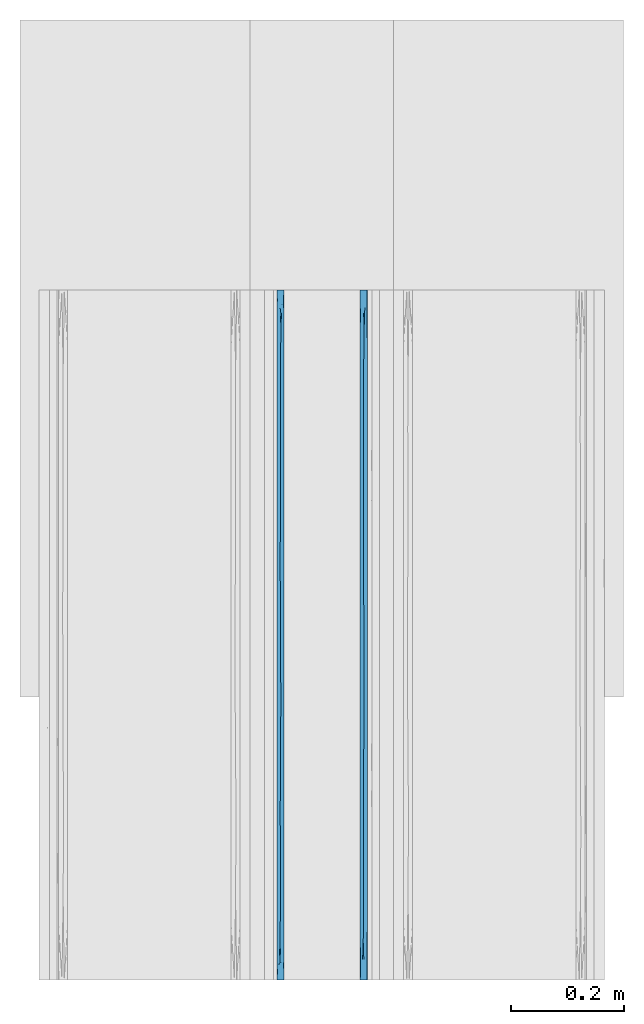
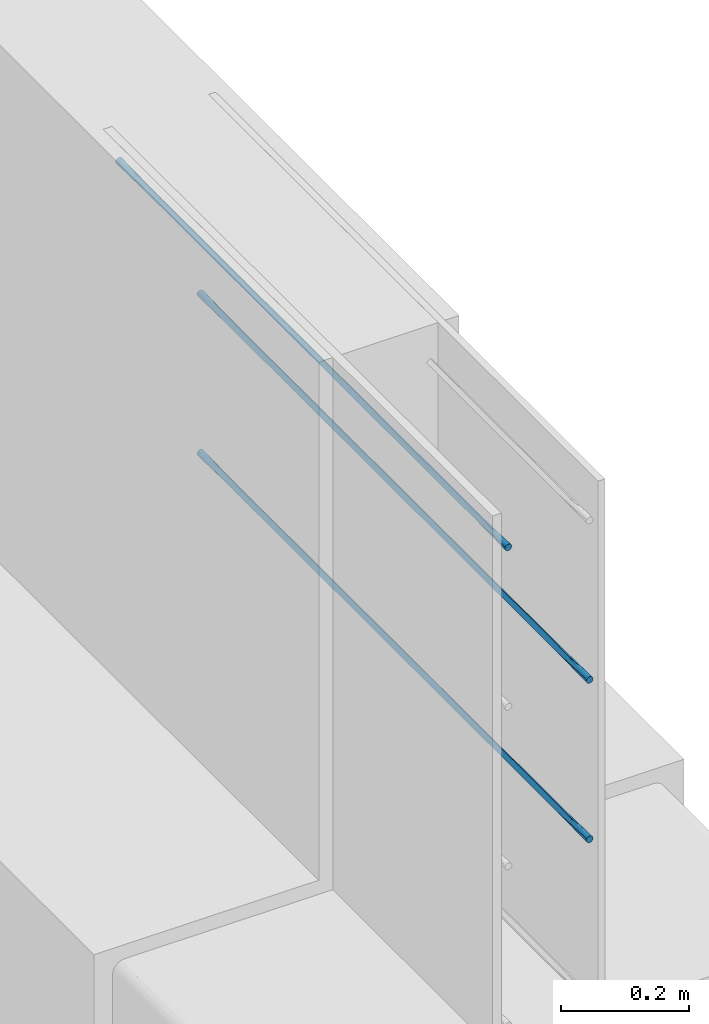
# One storey, part 9 of 10: 3 walls.
"""IFC2X3 building model written with IfcOpenShell, lengths in feet."""

from ifc_helpers import new_model, entity, si_unit, converted_unit, derived_unit, direction, frame, origin, place, context, subcontext, project, spatial, faceted_brep, material, type_object, element, save


model = new_model("IFC2X3")

# Units and contexts
model_context = context("Model", 3, precision=0.0001, world=origin(), true_north=direction((6.12303176911189e-17, 1.0)))
body_context = subcontext(model_context, "Body", "Model", "MODEL_VIEW")
ifc_project = project(units=[converted_unit("LENGTHUNIT", "FOOT", entity("IfcRatioMeasure", 0.3048), si_unit("LENGTHUNIT", "METRE"), dimensions=[1, 0, 0, 0, 0, 0, 0]), converted_unit("AREAUNIT", "SQUARE FOOT", entity("IfcRatioMeasure", 0.09290304), si_unit("AREAUNIT", "SQUARE_METRE"), dimensions=[2, 0, 0, 0, 0, 0, 0]), converted_unit("VOLUMEUNIT", "CUBIC FOOT", entity("IfcRatioMeasure", 0.028316846592), si_unit("VOLUMEUNIT", "CUBIC_METRE"), dimensions=[3, 0, 0, 0, 0, 0, 0]), converted_unit("PLANEANGLEUNIT", "DEGREE", entity("IfcRatioMeasure", 0.0174532925199433), si_unit("PLANEANGLEUNIT", "RADIAN"), dimensions=[0, 0, 0, 0, 0, 0, 0]), si_unit("MASSUNIT", "GRAM", prefix="KILO"), derived_unit("MASSDENSITYUNIT", [(si_unit("MASSUNIT", "GRAM", prefix="KILO"), 1), (si_unit("LENGTHUNIT", "METRE"), -3)]), si_unit("TIMEUNIT", "SECOND"), si_unit("FREQUENCYUNIT", "HERTZ"), si_unit("THERMODYNAMICTEMPERATUREUNIT", "DEGREE_CELSIUS"), derived_unit("THERMALTRANSMITTANCEUNIT", [(si_unit("MASSUNIT", "GRAM", prefix="KILO"), 1), (si_unit("THERMODYNAMICTEMPERATUREUNIT", "KELVIN"), -1), (si_unit("TIMEUNIT", "SECOND"), -3)]), derived_unit("VOLUMETRICFLOWRATEUNIT", [(si_unit("LENGTHUNIT", "METRE"), 3), (si_unit("TIMEUNIT", "SECOND"), -1)]), si_unit("ELECTRICCURRENTUNIT", "AMPERE"), si_unit("ELECTRICVOLTAGEUNIT", "VOLT"), si_unit("POWERUNIT", "WATT"), si_unit("FORCEUNIT", "NEWTON", prefix="KILO"), si_unit("ILLUMINANCEUNIT", "LUX"), si_unit("LUMINOUSFLUXUNIT", "LUMEN"), si_unit("LUMINOUSINTENSITYUNIT", "CANDELA"), derived_unit("USERDEFINED", [(si_unit("MASSUNIT", "GRAM", prefix="KILO"), -1), (si_unit("LENGTHUNIT", "METRE"), -2), (si_unit("TIMEUNIT", "SECOND"), 3), (si_unit("LUMINOUSFLUXUNIT", "LUMEN"), 1)]), derived_unit("LINEARVELOCITYUNIT", [(si_unit("LENGTHUNIT", "METRE"), 1), (si_unit("TIMEUNIT", "SECOND"), -1)]), si_unit("PRESSUREUNIT", "PASCAL"), derived_unit("USERDEFINED", [(si_unit("LENGTHUNIT", "METRE"), -2), (si_unit("MASSUNIT", "GRAM", prefix="KILO"), 1), (si_unit("TIMEUNIT", "SECOND"), -2)])], contexts=[model_context])

# Site, building, storey
site_placement = place(None, origin())
site = spatial("IfcSite", under=ifc_project, at=site_placement, CompositionType="ELEMENT")
building_placement = place(site_placement, origin())
building = spatial("IfcBuilding", under=site, at=building_placement, CompositionType="ELEMENT")
storey_placement = place(building_placement, frame((0.0, 0.0, 11.2604166666667)))
storey = spatial("IfcBuildingStorey", under=building, at=storey_placement, Name="2ND FLOOR", CompositionType="ELEMENT", Elevation=11.2604166666667)

# Walls
ifc_material = material()
wall_type_1 = type_object("IfcWallType", Name="Generic Models 1", PredefinedType="NOTDEFINED", material=ifc_material)
wall_1_placement = place(storey_placement, frame((1429.90087203322, 0.249999999995825, 4.90503341074841), z_axis=(0.0, 0.0, 1.0), x_axis=(0.0, 1.0, 0.0)))
element("IfcWall", 1, at=wall_1_placement, inside=storey, type_object=wall_type_1, material=ifc_material, Name="Generic Models 98:Generic Models 1", ObjectType="Generic Models 98:Generic Models 1", context=body_context, shape_type="Brep", body=[
    faceted_brep([(4.0, -0.0262253967728157, 0.0409567880476871), (4.0, -0.03125, 0.0388755292455087), (4.0, -0.0355647246078661, 0.0355647246080508), (4.0, -0.038875529245388, 0.03125), (4.0, -0.0409567880476516, 0.0262253967729684), (4.0, -0.0416666666665151, 0.0208333333333321), (4.0, -0.0409567880476516, 0.0154412698936959), (4.0, -0.038875529245388, 0.0104166666666643), (4.0, -0.0355647246078661, 0.00610194205861347), (4.0, -0.03125, 0.00279113742115555), (4.0, -0.0262253967728157, 0.0007098786189772), (4.0, -0.0208333333332575, 0.0), (4.0, -0.0154412698936994, 0.0007098786189772), (4.0, -0.0104166666665151, 0.00279113742115555), (4.0, -0.006101942058649, 0.00610194205861347), (4.0, -0.00279113742112713, 0.0104166666666643), (4.0, -0.000709878618863513, 0.0154412698936959), (4.0, 0.0, 0.0208333333333321), (4.0, -0.000709878618863513, 0.0262253967729684), (4.0, -0.00279113742112713, 0.03125), (4.0, -0.006101942058649, 0.0355647246080508), (4.0, -0.0104166666665151, 0.0388755292455087), (4.0, -0.0154412698936994, 0.0409567880476871), (4.0, -0.0208333333332575, 0.0416666666666643), (0.0, -0.0262253967728157, 0.000709878618984305), (0.0, -0.03125, 0.00279113742116266), (0.0, -0.0355647246078661, 0.00610194205862058), (0.0, -0.038875529245388, 0.0104166666666714), (0.0, -0.0409567880476516, 0.015441269893703), (0.0, -0.0416666666665151, 0.0208333333333393), (0.0, -0.0409567880476516, 0.0262253967729755), (0.0, -0.038875529245388, 0.0312500000000071), (0.0, -0.0355647246078661, 0.0355647246080579), (0.0, -0.03125, 0.0388755292455159), (0.0, -0.0262253967728157, 0.0409567880476942), (0.0, -0.0208333333332575, 0.0416666666666714), (0.0, -0.0154412698936994, 0.0409567880476942), (0.0, -0.0104166666665151, 0.0388755292455159), (0.0, -0.006101942058649, 0.0355647246080579), (0.0, -0.00279113742112713, 0.0312500000000071), (0.0, -0.000709878618863513, 0.0262253967729755), (0.0, 0.0, 0.0208333333333393), (0.0, -0.000709878618863513, 0.015441269893703), (0.0, -0.00279113742112713, 0.0104166666666714), (0.0, -0.006101942058649, 0.00610194205862058), (0.0, -0.0104166666665151, 0.00279113742116266), (0.0, -0.0154412698936994, 0.000709878618984305), (0.0, -0.0208333333332575, 0.0), (2.14388402114763, -0.0200322252712795, 1.54082770080777e-05), (1.8749999873482, -0.0201164472750861, 1.23378682417297e-05), (2.0, 0.0, 0.0208333333333357), (0.2209945797568, -0.0235526290068719, 0.000178232055045413), (3.78349365025041, -0.0181140376355415, 0.000178232058182459), (0.288675181168509, -0.0416666666665151, 0.0208333333333393), (2.55662427510468, -0.0416666666667425, 0.0208333333333357), (2.39350545093993, -0.0230795128859427, 0.000121441696034452), (2.72964779378728, -0.0208333333494011, 0.0), (3.71132487914723, -0.0416666666665151, 0.0208333333333321), (0.959427115258349, -0.0225483860315308, 7.07137486202214e-05), (0.78867513369125, 0.0, 0.0208333333333357), (0.845299480274044, 0.0, 0.0208333333333393), (1.0, 0.0, 0.0208333333333393), (1.05662434259908, 0.0, 0.0208333333333357), (1.25, 0.0, 0.0208333333333357), (1.75, 0.0, 0.0208333333333357), (1.62498580610317, -0.0185830665252524, 0.000121885361959784), (3.71132486630875, 0.0, 0.0208333333333321), (0.28867513369125, 0.0, 0.0208333333333393), (0.5773502673825, 0.0, 0.0208333333333357), (0.711324858555642, -0.0208333333287101, 0.0), (0.44198915950752, -0.0208333333268911, 0.0), (3.13397456595189, 0.0, 0.0208333333333321), (3.42264969964314, 0.0, 0.0208333333333321), (3.27831213705374, -0.0208333333389419, 0.0), (2.98963700310718, -0.0208333333653172, 0.0), (2.63397456595189, 0.0, 0.0208333333333357), (2.84529943226064, 0.0, 0.0208333333333357), (3.56698727175129, -0.0208333335056068, 0.0), (3.42264975829447, -0.0416666666665151, 0.0208333333333321), (3.1339746374417, -0.0416666666665151, 0.0208333333333357), (2.84529945627319, -0.0416666666662877, 0.0208333333333321), (2.6339745906388, -0.0416666666665151, 0.0208333333333357), (0.845299486431061, -0.0416666666665151, 0.0208333333333393), (0.788675136453734, -0.0416666666662877, 0.0208333333333357), (0.577350302021276, -0.0416666666667425, 0.0208333333333357), (1.97927407112088, 0.0, 0.0208333333333357), (1.97927403339915, -0.0416666666665151, 0.0208333333333357), (2.26794915425192, -0.0416666666662877, 0.0208333333333357), (2.21132486354627, -0.0416666666665151, 0.0208333333333357), (2.0, -0.0416666666665151, 0.0208333333333357), (2.21132486630875, 0.0, 0.0208333333333357), (2.26794921266759, 0.0, 0.0208333333333357), (2.42264969964314, 0.0, 0.0208333333333357), (2.55662432324038, 0.0, 0.0208333333333357), (1.75, -0.0416666666665151, 0.0208333333333357), (1.69059891254638, -0.0416666666665151, 0.0208333333333357), (1.47927402585968, -0.0416666666665151, 0.0208333333333357), (1.3749999905963, -0.0202049447002537, 9.47909105519784e-06), (2.42264972709253, -0.0416666666665151, 0.0208333333333357), (1.26794920492411, 0.0, 0.0208333333333357), (1.47927406724915, 0.0, 0.0208333333333357), (1.5, 0.0, 0.0208333333333357), (1.26794919948872, -0.0416666666665151, 0.0208333333333357), (1.25, -0.0416666666665151, 0.0208333333333357), (1.05662437311776, -0.0416666666665151, 0.0208333333333357), (1.0, -0.0416666666665151, 0.0208333333333393), (1.5, -0.0416666666667425, 0.0208333333333357), (1.69059892957418, 0.0, 0.0208333333333357), (2.14388402115656, -0.0216344413906882, 0.0416512583898339), (1.87499998744159, -0.0215502193923385, 0.0416543287983941), (0.220994579714599, -0.0181140376603253, 0.0414884346117397), (3.78349365012031, -0.0235526293449766, 0.0414884345671211), (2.3935054510086, -0.0185871537623825, 0.0415452249686439), (2.72964779341247, -0.0208333333278006, 0.0416666666666679), (0.959427115233259, -0.0191182806272536, 0.0415959529174224), (1.62498580618022, -0.023083600129894, 0.0415447813059444), (0.711324858513196, -0.0208333333348492, 0.0416666666666714), (0.441989159426871, -0.0208333333353039, 0.0416666666666714), (3.27831213726184, -0.0208333333314386, 0.0416666666666679), (2.9896370028857, -0.020833333322571, 0.0416666666666679), (3.56698727186825, -0.0208333332750499, 0.0416666666666679), (1.37499999066007, -0.0214617219517095, 0.0416571875760567)], [[[0, 1, 2, 3, 4, 5, 6, 7, 8, 9, 10, 11, 12, 13, 14, 15, 16, 17, 18, 19, 20, 21, 22, 23]], [[24, 25, 26, 27, 28, 29, 30, 31, 32, 33, 34, 35, 36, 37, 38, 39, 40, 41, 42, 43, 44, 45, 46, 47]], [[48, 49, 50]], [[24, 47, 51]], [[52, 9, 8]], [[27, 53, 28]], [[54, 55, 56]], [[51, 25, 24]], [[57, 7, 6]], [[57, 8, 7]], [[52, 13, 12]], [[6, 5, 57]], [[29, 28, 53]], [[58, 59, 60, 61, 62, 63]], [[64, 49, 65]], [[52, 14, 13]], [[66, 17, 16]], [[42, 41, 67]], [[42, 67, 43]], [[68, 59, 69, 70, 67]], [[71, 72, 73, 74, 56, 75, 76]], [[66, 77, 72]], [[78, 79, 80, 81, 54, 56, 74, 73]], [[69, 82, 83, 84, 53, 70]], [[78, 77, 57]], [[77, 52, 57]], [[49, 64, 85, 50]], [[48, 86, 49]], [[15, 66, 16]], [[47, 46, 51]], [[14, 52, 15]], [[70, 53, 51]], [[82, 69, 58]], [[69, 59, 58]], [[51, 26, 25]], [[44, 43, 67]], [[10, 52, 11]], [[45, 51, 46]], [[67, 70, 51]], [[44, 51, 45]], [[51, 27, 26]], [[51, 44, 67]], [[57, 52, 8]], [[48, 87, 88, 89, 86]], [[9, 52, 10]], [[55, 90, 91, 92, 93, 75]], [[53, 27, 51]], [[49, 86, 94, 95]], [[90, 55, 48]], [[73, 72, 77]], [[12, 11, 52]], [[73, 77, 78]], [[77, 66, 52]], [[66, 15, 52]], [[87, 48, 55]], [[55, 75, 56]], [[65, 96, 97]], [[55, 54, 98, 87]], [[97, 63, 99, 100, 101]], [[58, 102, 103, 104, 105, 82]], [[63, 97, 58]], [[97, 101, 65]], [[65, 95, 106, 96]], [[65, 101, 107, 64]], [[95, 65, 49]], [[102, 58, 97]], [[96, 102, 97]], [[48, 50, 90]], [[108, 109, 89]], [[36, 35, 110]], [[111, 21, 20]], [[39, 67, 40]], [[93, 112, 113]], [[110, 37, 36]], [[66, 19, 18]], [[66, 20, 19]], [[111, 1, 0]], [[18, 17, 66]], [[41, 40, 67]], [[114, 83, 82, 105, 104, 103]], [[94, 109, 115]], [[111, 2, 1]], [[57, 5, 4]], [[30, 29, 53]], [[30, 53, 31]], [[84, 83, 116, 117, 53]], [[79, 78, 118, 119, 113, 81, 80]], [[116, 83, 114]], [[72, 71, 76, 75, 93, 113, 119, 118]], [[116, 60, 59, 68, 67, 117]], [[72, 118, 120, 66]], [[120, 111, 66]], [[109, 94, 86, 89]], [[108, 85, 109]], [[3, 57, 4]], [[2, 111, 3]], [[34, 110, 35]], [[117, 67, 110]], [[60, 116, 114]], [[57, 120, 118, 78]], [[110, 38, 37]], [[32, 31, 53]], [[22, 111, 23]], [[33, 110, 34]], [[53, 117, 110]], [[32, 110, 33]], [[110, 39, 38]], [[110, 32, 53]], [[66, 111, 20]], [[108, 91, 90, 50, 85]], [[21, 111, 22]], [[112, 88, 87, 98, 54, 81]], [[67, 39, 110]], [[109, 85, 64, 107]], [[88, 112, 108]], [[0, 23, 111]], [[120, 57, 111]], [[57, 3, 111]], [[91, 108, 112]], [[112, 81, 113]], [[115, 100, 121]], [[112, 93, 92, 91]], [[121, 103, 102, 96, 106]], [[114, 99, 63, 62, 61, 60]], [[103, 121, 114]], [[121, 106, 115]], [[115, 107, 101, 100]], [[115, 106, 95, 94]], [[107, 115, 109]], [[99, 114, 121]], [[100, 99, 121]], [[108, 89, 88]]]),
])
wall_type_2 = type_object("IfcWallType", Name="Generic Models 1", PredefinedType="NOTDEFINED", material=ifc_material)
wall_2_placement = place(storey_placement, frame((1429.90087203322, 0.249999999995825, 5.90503341074841), z_axis=(0.0, 0.0, 1.0), x_axis=(0.0, 1.0, 0.0)))
element("IfcWall", 2, at=wall_2_placement, inside=storey, type_object=wall_type_2, material=ifc_material, Name="Generic Models 122:Generic Models 1", ObjectType="Generic Models 122:Generic Models 1", context=body_context, shape_type="Brep", body=[
    faceted_brep([(4.0, -0.0262253967728157, 0.0409567880476871), (4.0, -0.03125, 0.0388755292455087), (4.0, -0.0355647246078661, 0.0355647246080508), (4.0, -0.038875529245388, 0.03125), (4.0, -0.0409567880476516, 0.0262253967729684), (4.0, -0.0416666666665151, 0.0208333333333321), (4.0, -0.0409567880476516, 0.0154412698936959), (4.0, -0.038875529245388, 0.0104166666666643), (4.0, -0.0355647246078661, 0.00610194205861347), (4.0, -0.03125, 0.00279113742115555), (4.0, -0.0262253967728157, 0.0007098786189772), (4.0, -0.0208333333332575, 0.0), (4.0, -0.0154412698936994, 0.0007098786189772), (4.0, -0.0104166666665151, 0.00279113742115555), (4.0, -0.006101942058649, 0.00610194205861347), (4.0, -0.00279113742112713, 0.0104166666666643), (4.0, -0.000709878618863513, 0.0154412698936959), (4.0, 0.0, 0.0208333333333321), (4.0, -0.000709878618863513, 0.0262253967729684), (4.0, -0.00279113742112713, 0.03125), (4.0, -0.006101942058649, 0.0355647246080508), (4.0, -0.0104166666665151, 0.0388755292455087), (4.0, -0.0154412698936994, 0.0409567880476871), (4.0, -0.0208333333332575, 0.0416666666666643), (0.0, -0.0262253967728157, 0.000709878618984305), (0.0, -0.03125, 0.00279113742116266), (0.0, -0.0355647246078661, 0.00610194205862058), (0.0, -0.038875529245388, 0.0104166666666714), (0.0, -0.0409567880476516, 0.015441269893703), (0.0, -0.0416666666665151, 0.0208333333333393), (0.0, -0.0409567880476516, 0.0262253967729755), (0.0, -0.038875529245388, 0.0312500000000071), (0.0, -0.0355647246078661, 0.0355647246080579), (0.0, -0.03125, 0.0388755292455159), (0.0, -0.0262253967728157, 0.0409567880476942), (0.0, -0.0208333333332575, 0.0416666666666714), (0.0, -0.0154412698936994, 0.0409567880476942), (0.0, -0.0104166666665151, 0.0388755292455159), (0.0, -0.006101942058649, 0.0355647246080579), (0.0, -0.00279113742112713, 0.0312500000000071), (0.0, -0.000709878618863513, 0.0262253967729755), (0.0, 0.0, 0.0208333333333393), (0.0, -0.000709878618863513, 0.015441269893703), (0.0, -0.00279113742112713, 0.0104166666666714), (0.0, -0.006101942058649, 0.00610194205862058), (0.0, -0.0104166666665151, 0.00279113742116266), (0.0, -0.0154412698936994, 0.000709878618984305), (0.0, -0.0208333333332575, 0.0), (2.14388402114763, -0.0200322252712795, 1.54082770080777e-05), (1.8749999873482, -0.0201164472750861, 1.23378682417297e-05), (2.0, 0.0, 0.0208333333333357), (0.2209945797568, -0.0235526290068719, 0.000178232055045413), (3.78349365025041, -0.0181140376355415, 0.000178232058182459), (0.288675181168509, -0.0416666666665151, 0.0208333333333393), (2.55662427510468, -0.0416666666667425, 0.0208333333333357), (2.39350545093993, -0.0230795128859427, 0.000121441696034452), (2.72964779378728, -0.0208333333494011, 0.0), (3.71132487914723, -0.0416666666665151, 0.0208333333333321), (0.959427115258349, -0.0225483860315308, 7.07137486202214e-05), (0.78867513369125, 0.0, 0.0208333333333393), (0.845299480274044, 0.0, 0.0208333333333393), (1.0, 0.0, 0.0208333333333393), (1.05662434259908, 0.0, 0.0208333333333393), (1.25, 0.0, 0.0208333333333357), (1.75, 0.0, 0.0208333333333357), (1.62498580610317, -0.0185830665252524, 0.000121885361959784), (3.71132486630875, 0.0, 0.0208333333333321), (0.28867513369125, 0.0, 0.0208333333333393), (0.5773502673825, 0.0, 0.0208333333333357), (0.711324858555642, -0.0208333333287101, 0.0), (0.44198915950752, -0.0208333333268911, 0.0), (3.13397456595189, 0.0, 0.0208333333333357), (3.42264969964314, 0.0, 0.0208333333333321), (3.27831213705374, -0.0208333333389419, 0.0), (2.98963700310718, -0.0208333333653172, 0.0), (2.63397456595189, 0.0, 0.0208333333333357), (2.84529943226064, 0.0, 0.0208333333333357), (3.56698727175129, -0.0208333335056068, 0.0), (3.42264975829447, -0.0416666666665151, 0.0208333333333321), (3.1339746374417, -0.0416666666665151, 0.0208333333333321), (2.84529945627319, -0.0416666666662877, 0.0208333333333357), (2.6339745906388, -0.0416666666665151, 0.0208333333333357), (0.845299486431061, -0.0416666666665151, 0.0208333333333393), (0.788675136453734, -0.0416666666662877, 0.0208333333333357), (0.577350302021276, -0.0416666666667425, 0.0208333333333393), (1.97927407112088, 0.0, 0.0208333333333357), (1.97927403339915, -0.0416666666665151, 0.0208333333333357), (2.26794915425192, -0.0416666666662877, 0.0208333333333357), (2.21132486354627, -0.0416666666665151, 0.0208333333333357), (2.0, -0.0416666666665151, 0.0208333333333357), (2.21132486630875, 0.0, 0.0208333333333357), (2.26794921266759, 0.0, 0.0208333333333357), (2.42264969964314, 0.0, 0.0208333333333357), (2.55662432324038, 0.0, 0.0208333333333357), (1.75, -0.0416666666665151, 0.0208333333333357), (1.69059891254638, -0.0416666666665151, 0.0208333333333357), (1.47927402585968, -0.0416666666665151, 0.0208333333333357), (1.3749999905963, -0.0202049447002537, 9.47909105519784e-06), (2.42264972709253, -0.0416666666665151, 0.0208333333333357), (1.26794920492411, 0.0, 0.0208333333333357), (1.47927406724915, 0.0, 0.0208333333333357), (1.5, 0.0, 0.0208333333333357), (1.26794919948872, -0.0416666666665151, 0.0208333333333357), (1.25, -0.0416666666665151, 0.0208333333333357), (1.05662437311776, -0.0416666666665151, 0.0208333333333357), (1.0, -0.0416666666665151, 0.0208333333333393), (1.5, -0.0416666666667425, 0.0208333333333357), (1.69059892957418, 0.0, 0.0208333333333357), (2.14388402115656, -0.0216344413906882, 0.0416512583898339), (1.87499998744159, -0.0215502193923385, 0.0416543287983941), (0.220994579714599, -0.0181140376603253, 0.0414884346117397), (3.78349365012031, -0.0235526293449766, 0.0414884345671211), (2.3935054510086, -0.0185871537623825, 0.0415452249686439), (2.72964779341247, -0.0208333333278006, 0.0416666666666679), (0.959427115233259, -0.0191182806272536, 0.0415959529174224), (1.62498580618022, -0.023083600129894, 0.0415447813059444), (0.711324858513196, -0.0208333333348492, 0.0416666666666714), (0.441989159426871, -0.0208333333353039, 0.0416666666666714), (3.27831213726184, -0.0208333333314386, 0.0416666666666679), (2.9896370028857, -0.020833333322571, 0.0416666666666679), (3.56698727186825, -0.0208333332750499, 0.0416666666666679), (1.37499999066007, -0.0214617219517095, 0.0416571875760567)], [[[0, 1, 2, 3, 4, 5, 6, 7, 8, 9, 10, 11, 12, 13, 14, 15, 16, 17, 18, 19, 20, 21, 22, 23]], [[24, 25, 26, 27, 28, 29, 30, 31, 32, 33, 34, 35, 36, 37, 38, 39, 40, 41, 42, 43, 44, 45, 46, 47]], [[48, 49, 50]], [[24, 47, 51]], [[52, 9, 8]], [[27, 53, 28]], [[54, 55, 56]], [[51, 25, 24]], [[57, 7, 6]], [[57, 8, 7]], [[52, 13, 12]], [[6, 5, 57]], [[29, 28, 53]], [[58, 59, 60, 61, 62, 63]], [[64, 49, 65]], [[52, 14, 13]], [[66, 17, 16]], [[42, 41, 67]], [[42, 67, 43]], [[68, 59, 69, 70, 67]], [[71, 72, 73, 74, 56, 75, 76]], [[66, 77, 72]], [[78, 79, 80, 81, 54, 56, 74, 73]], [[69, 82, 83, 84, 53, 70]], [[78, 77, 57]], [[77, 52, 57]], [[49, 64, 85, 50]], [[48, 86, 49]], [[15, 66, 16]], [[47, 46, 51]], [[14, 52, 15]], [[70, 53, 51]], [[82, 69, 58]], [[69, 59, 58]], [[51, 26, 25]], [[44, 43, 67]], [[10, 52, 11]], [[45, 51, 46]], [[67, 70, 51]], [[44, 51, 45]], [[51, 27, 26]], [[51, 44, 67]], [[57, 52, 8]], [[48, 87, 88, 89, 86]], [[9, 52, 10]], [[55, 90, 91, 92, 93, 75]], [[53, 27, 51]], [[49, 86, 94, 95]], [[90, 55, 48]], [[73, 72, 77]], [[12, 11, 52]], [[73, 77, 78]], [[77, 66, 52]], [[66, 15, 52]], [[87, 48, 55]], [[55, 75, 56]], [[65, 96, 97]], [[55, 54, 98, 87]], [[97, 63, 99, 100, 101]], [[58, 102, 103, 104, 105, 82]], [[63, 97, 58]], [[97, 101, 65]], [[65, 95, 106, 96]], [[65, 101, 107, 64]], [[95, 65, 49]], [[102, 58, 97]], [[96, 102, 97]], [[48, 50, 90]], [[108, 109, 89]], [[36, 35, 110]], [[111, 21, 20]], [[39, 67, 40]], [[93, 112, 113]], [[110, 37, 36]], [[66, 19, 18]], [[66, 20, 19]], [[111, 1, 0]], [[18, 17, 66]], [[41, 40, 67]], [[114, 83, 82, 105, 104, 103]], [[94, 109, 115]], [[111, 2, 1]], [[57, 5, 4]], [[30, 29, 53]], [[30, 53, 31]], [[84, 83, 116, 117, 53]], [[79, 78, 118, 119, 113, 81, 80]], [[116, 83, 114]], [[72, 71, 76, 75, 93, 113, 119, 118]], [[116, 60, 59, 68, 67, 117]], [[72, 118, 120, 66]], [[120, 111, 66]], [[109, 94, 86, 89]], [[108, 85, 109]], [[3, 57, 4]], [[2, 111, 3]], [[34, 110, 35]], [[117, 67, 110]], [[60, 116, 114]], [[57, 120, 118, 78]], [[110, 38, 37]], [[32, 31, 53]], [[22, 111, 23]], [[33, 110, 34]], [[53, 117, 110]], [[32, 110, 33]], [[110, 39, 38]], [[110, 32, 53]], [[66, 111, 20]], [[108, 91, 90, 50, 85]], [[21, 111, 22]], [[112, 88, 87, 98, 54, 81]], [[67, 39, 110]], [[109, 85, 64, 107]], [[88, 112, 108]], [[0, 23, 111]], [[120, 57, 111]], [[57, 3, 111]], [[91, 108, 112]], [[112, 81, 113]], [[115, 100, 121]], [[112, 93, 92, 91]], [[121, 103, 102, 96, 106]], [[114, 99, 63, 62, 61, 60]], [[103, 121, 114]], [[121, 106, 115]], [[115, 107, 101, 100]], [[115, 106, 95, 94]], [[107, 115, 109]], [[99, 114, 121]], [[100, 99, 121]], [[108, 89, 88]]]),
])
wall_type_3 = type_object("IfcWallType", Name="Generic Models 1", PredefinedType="NOTDEFINED", material=ifc_material)
wall_3_placement = place(storey_placement, frame((1429.41837203322, 0.249999999977769, 6.90503341074841), z_axis=(0.0, 0.0, 1.0), x_axis=(0.0, 1.0, 0.0)))
element("IfcWall", 3, at=wall_3_placement, inside=storey, type_object=wall_type_3, material=ifc_material, Name="Generic Models 230:Generic Models 1", ObjectType="Generic Models 230:Generic Models 1", context=body_context, shape_type="Brep", body=[
    faceted_brep([(4.0, -0.0262253967728157, 0.0409567880476871), (4.0, -0.03125, 0.0388755292455087), (4.0, -0.0355647246078661, 0.0355647246080508), (4.0, -0.038875529245388, 0.03125), (4.0, -0.0409567880476516, 0.0262253967729684), (4.0, -0.0416666666665151, 0.0208333333333321), (4.0, -0.0409567880476516, 0.0154412698936959), (4.0, -0.038875529245388, 0.0104166666666643), (4.0, -0.0355647246078661, 0.00610194205861347), (4.0, -0.03125, 0.00279113742115555), (4.0, -0.0262253967728157, 0.0007098786189772), (4.0, -0.0208333333332575, 0.0), (4.0, -0.0154412698936994, 0.0007098786189772), (4.0, -0.0104166666665151, 0.00279113742115555), (4.0, -0.006101942058649, 0.00610194205861347), (4.0, -0.00279113742112713, 0.0104166666666643), (4.0, -0.000709878618863513, 0.0154412698936959), (4.0, 0.0, 0.0208333333333321), (4.0, -0.000709878618863513, 0.0262253967729684), (4.0, -0.00279113742112713, 0.03125), (4.0, -0.006101942058649, 0.0355647246080508), (4.0, -0.0104166666665151, 0.0388755292455087), (4.0, -0.0154412698936994, 0.0409567880476871), (4.0, -0.0208333333332575, 0.0416666666666643), (0.0, -0.0262253967728157, 0.000709878618984305), (0.0, -0.03125, 0.00279113742116266), (0.0, -0.0355647246078661, 0.00610194205862058), (0.0, -0.038875529245388, 0.0104166666666714), (0.0, -0.0409567880476516, 0.015441269893703), (0.0, -0.0416666666665151, 0.0208333333333393), (0.0, -0.0409567880476516, 0.0262253967729755), (0.0, -0.038875529245388, 0.0312500000000071), (0.0, -0.0355647246078661, 0.0355647246080579), (0.0, -0.03125, 0.0388755292455159), (0.0, -0.0262253967728157, 0.0409567880476942), (0.0, -0.0208333333332575, 0.0416666666666714), (0.0, -0.0154412698936994, 0.0409567880476942), (0.0, -0.0104166666665151, 0.0388755292455159), (0.0, -0.006101942058649, 0.0355647246080579), (0.0, -0.00279113742112713, 0.0312500000000071), (0.0, -0.000709878618863513, 0.0262253967729755), (0.0, 0.0, 0.0208333333333393), (0.0, -0.000709878618863513, 0.015441269893703), (0.0, -0.00279113742112713, 0.0104166666666714), (0.0, -0.006101942058649, 0.00610194205862058), (0.0, -0.0104166666665151, 0.00279113742116266), (0.0, -0.0154412698936994, 0.000709878618984305), (0.0, -0.0208333333332575, 0.0), (2.14388402114763, -0.0200322252712795, 1.54082770080777e-05), (1.8749999873482, -0.0201164472750861, 1.23378682417297e-05), (2.0, 0.0, 0.0208333333333357), (0.2209945797568, -0.0235526290068719, 0.000178232055045413), (3.78349365025041, -0.0181140376355415, 0.000178232058182459), (0.288675181168509, -0.0416666666665151, 0.0208333333333393), (2.55662427510468, -0.0416666666667425, 0.0208333333333357), (2.39350545093993, -0.0230795128859427, 0.000121441696034452), (2.72964779378728, -0.0208333333494011, 0.0), (3.71132487914723, -0.0416666666665151, 0.0208333333333321), (0.959427115258349, -0.0225483860315308, 7.07137486202214e-05), (0.78867513369125, 0.0, 0.0208333333333393), (0.845299480274044, 0.0, 0.0208333333333393), (1.0, 0.0, 0.0208333333333393), (1.05662434259908, 0.0, 0.0208333333333357), (1.25, 0.0, 0.0208333333333357), (1.75, 0.0, 0.0208333333333357), (1.62498580610317, -0.0185830665252524, 0.000121885361959784), (3.71132486630875, 0.0, 0.0208333333333321), (0.28867513369125, 0.0, 0.0208333333333393), (0.577350267382501, 0.0, 0.0208333333333393), (0.711324858555642, -0.0208333333287101, 0.0), (0.44198915950752, -0.0208333333268911, 0.0), (3.13397456595189, 0.0, 0.0208333333333357), (3.42264969964314, 0.0, 0.0208333333333321), (3.27831213705374, -0.0208333333389419, 0.0), (2.98963700310718, -0.0208333333653172, 0.0), (2.63397456595189, 0.0, 0.0208333333333357), (2.84529943226064, 0.0, 0.0208333333333357), (3.56698727175129, -0.0208333335056068, 0.0), (3.42264975829447, -0.0416666666665151, 0.0208333333333321), (3.1339746374417, -0.0416666666665151, 0.0208333333333357), (2.84529945627319, -0.0416666666662877, 0.0208333333333321), (2.6339745906388, -0.0416666666665151, 0.0208333333333357), (0.845299486431061, -0.0416666666665151, 0.0208333333333393), (0.788675136453734, -0.0416666666665151, 0.0208333333333357), (0.577350302021276, -0.0416666666665151, 0.0208333333333393), (1.97927407112088, 0.0, 0.0208333333333357), (1.97927403339915, -0.0416666666665151, 0.0208333333333357), (2.26794915425191, -0.0416666666662877, 0.0208333333333357), (2.21132486354627, -0.0416666666665151, 0.0208333333333357), (2.0, -0.0416666666665151, 0.0208333333333357), (2.21132486630875, 0.0, 0.0208333333333357), (2.26794921266759, 0.0, 0.0208333333333357), (2.42264969964314, 0.0, 0.0208333333333357), (2.55662432324038, 0.0, 0.0208333333333357), (1.75, -0.0416666666665151, 0.0208333333333357), (1.69059891254638, -0.0416666666665151, 0.0208333333333357), (1.47927402585968, -0.0416666666665151, 0.0208333333333357), (1.3749999905963, -0.0202049447002537, 9.47909105519784e-06), (2.42264972709253, -0.0416666666665151, 0.0208333333333357), (1.26794920492411, 0.0, 0.0208333333333357), (1.47927406724915, 0.0, 0.0208333333333357), (1.5, 0.0, 0.0208333333333357), (1.26794919948872, -0.0416666666665151, 0.0208333333333357), (1.25, -0.0416666666665151, 0.0208333333333357), (1.05662437311776, -0.0416666666665151, 0.0208333333333393), (1.0, -0.0416666666667425, 0.0208333333333393), (1.5, -0.0416666666665151, 0.0208333333333357), (1.69059892957418, 0.0, 0.0208333333333357), (2.14388402115656, -0.0216344413906882, 0.0416512583898339), (1.87499998744159, -0.0215502193923385, 0.0416543287983941), (0.220994579714599, -0.0181140376603253, 0.0414884346117397), (3.78349365012031, -0.0235526293449766, 0.0414884345671211), (2.3935054510086, -0.0185871537623825, 0.0415452249686439), (2.72964779341247, -0.0208333333278006, 0.0416666666666679), (0.959427115233259, -0.0191182806272536, 0.0415959529174224), (1.62498580618022, -0.023083600129894, 0.0415447813059444), (0.711324858513196, -0.0208333333348492, 0.0416666666666714), (0.441989159426871, -0.0208333333353039, 0.0416666666666714), (3.27831213726184, -0.0208333333314386, 0.0416666666666679), (2.9896370028857, -0.020833333322571, 0.0416666666666679), (3.56698727186825, -0.0208333332750499, 0.0416666666666679), (1.37499999066007, -0.0214617219517095, 0.0416571875760567)], [[[0, 1, 2, 3, 4, 5, 6, 7, 8, 9, 10, 11, 12, 13, 14, 15, 16, 17, 18, 19, 20, 21, 22, 23]], [[24, 25, 26, 27, 28, 29, 30, 31, 32, 33, 34, 35, 36, 37, 38, 39, 40, 41, 42, 43, 44, 45, 46, 47]], [[48, 49, 50]], [[24, 47, 51]], [[52, 9, 8]], [[27, 53, 28]], [[54, 55, 56]], [[51, 25, 24]], [[57, 7, 6]], [[57, 8, 7]], [[52, 13, 12]], [[6, 5, 57]], [[29, 28, 53]], [[58, 59, 60, 61, 62, 63]], [[64, 49, 65]], [[52, 14, 13]], [[66, 17, 16]], [[42, 41, 67]], [[42, 67, 43]], [[68, 59, 69, 70, 67]], [[71, 72, 73, 74, 56, 75, 76]], [[66, 77, 72]], [[78, 79, 80, 81, 54, 56, 74, 73]], [[69, 82, 83, 84, 53, 70]], [[78, 77, 57]], [[77, 52, 57]], [[49, 64, 85, 50]], [[48, 86, 49]], [[15, 66, 16]], [[47, 46, 51]], [[14, 52, 15]], [[70, 53, 51]], [[82, 69, 58]], [[69, 59, 58]], [[51, 26, 25]], [[44, 43, 67]], [[10, 52, 11]], [[45, 51, 46]], [[67, 70, 51]], [[44, 51, 45]], [[51, 27, 26]], [[51, 44, 67]], [[57, 52, 8]], [[48, 87, 88, 89, 86]], [[9, 52, 10]], [[55, 90, 91, 92, 93, 75]], [[53, 27, 51]], [[49, 86, 94, 95]], [[90, 55, 48]], [[73, 72, 77]], [[12, 11, 52]], [[73, 77, 78]], [[77, 66, 52]], [[66, 15, 52]], [[87, 48, 55]], [[55, 75, 56]], [[65, 96, 97]], [[55, 54, 98, 87]], [[97, 63, 99, 100, 101]], [[58, 102, 103, 104, 105, 82]], [[63, 97, 58]], [[97, 101, 65]], [[65, 95, 106, 96]], [[65, 101, 107, 64]], [[95, 65, 49]], [[102, 58, 97]], [[96, 102, 97]], [[48, 50, 90]], [[108, 109, 89]], [[36, 35, 110]], [[111, 21, 20]], [[39, 67, 40]], [[93, 112, 113]], [[110, 37, 36]], [[66, 19, 18]], [[66, 20, 19]], [[111, 1, 0]], [[18, 17, 66]], [[41, 40, 67]], [[114, 83, 82, 105, 104, 103]], [[94, 109, 115]], [[111, 2, 1]], [[57, 5, 4]], [[30, 29, 53]], [[30, 53, 31]], [[84, 83, 116, 117, 53]], [[79, 78, 118, 119, 113, 81, 80]], [[116, 83, 114]], [[72, 71, 76, 75, 93, 113, 119, 118]], [[116, 60, 59, 68, 67, 117]], [[72, 118, 120, 66]], [[120, 111, 66]], [[109, 94, 86, 89]], [[108, 85, 109]], [[3, 57, 4]], [[2, 111, 3]], [[34, 110, 35]], [[117, 67, 110]], [[60, 116, 114]], [[57, 120, 118, 78]], [[110, 38, 37]], [[32, 31, 53]], [[22, 111, 23]], [[33, 110, 34]], [[53, 117, 110]], [[32, 110, 33]], [[110, 39, 38]], [[110, 32, 53]], [[66, 111, 20]], [[108, 91, 90, 50, 85]], [[21, 111, 22]], [[112, 88, 87, 98, 54, 81]], [[67, 39, 110]], [[109, 85, 64, 107]], [[88, 112, 108]], [[0, 23, 111]], [[120, 57, 111]], [[57, 3, 111]], [[91, 108, 112]], [[112, 81, 113]], [[115, 100, 121]], [[112, 93, 92, 91]], [[121, 103, 102, 96, 106]], [[114, 99, 63, 62, 61, 60]], [[103, 121, 114]], [[121, 106, 115]], [[115, 107, 101, 100]], [[115, 106, 95, 94]], [[107, 115, 109]], [[99, 114, 121]], [[100, 99, 121]], [[108, 89, 88]]]),
])

save(model, "model.ifc")
